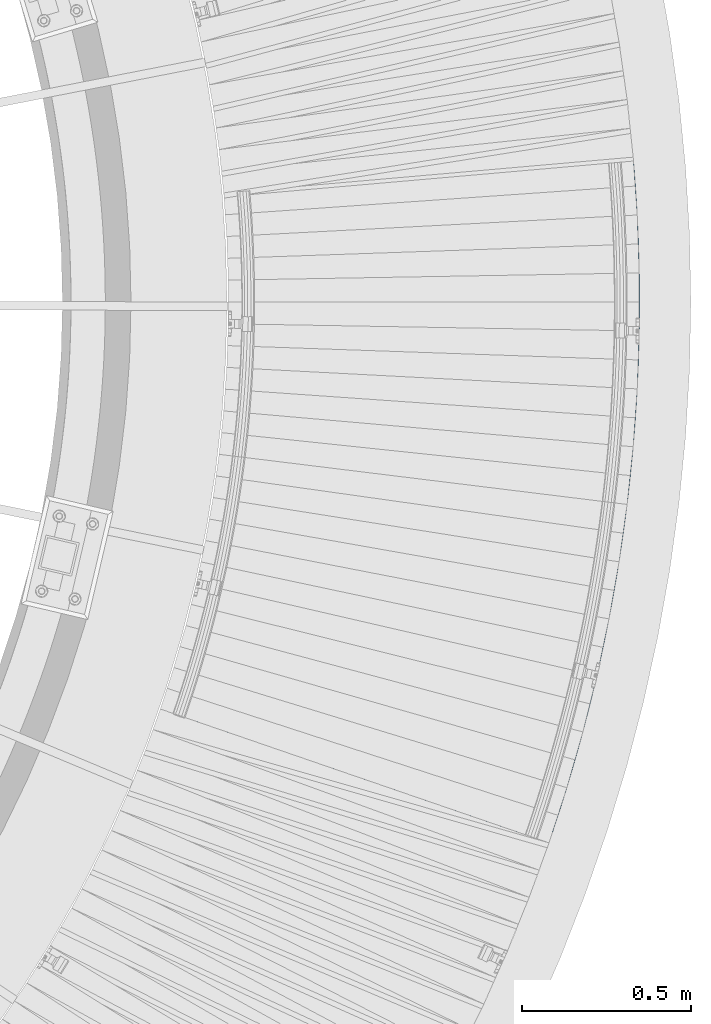
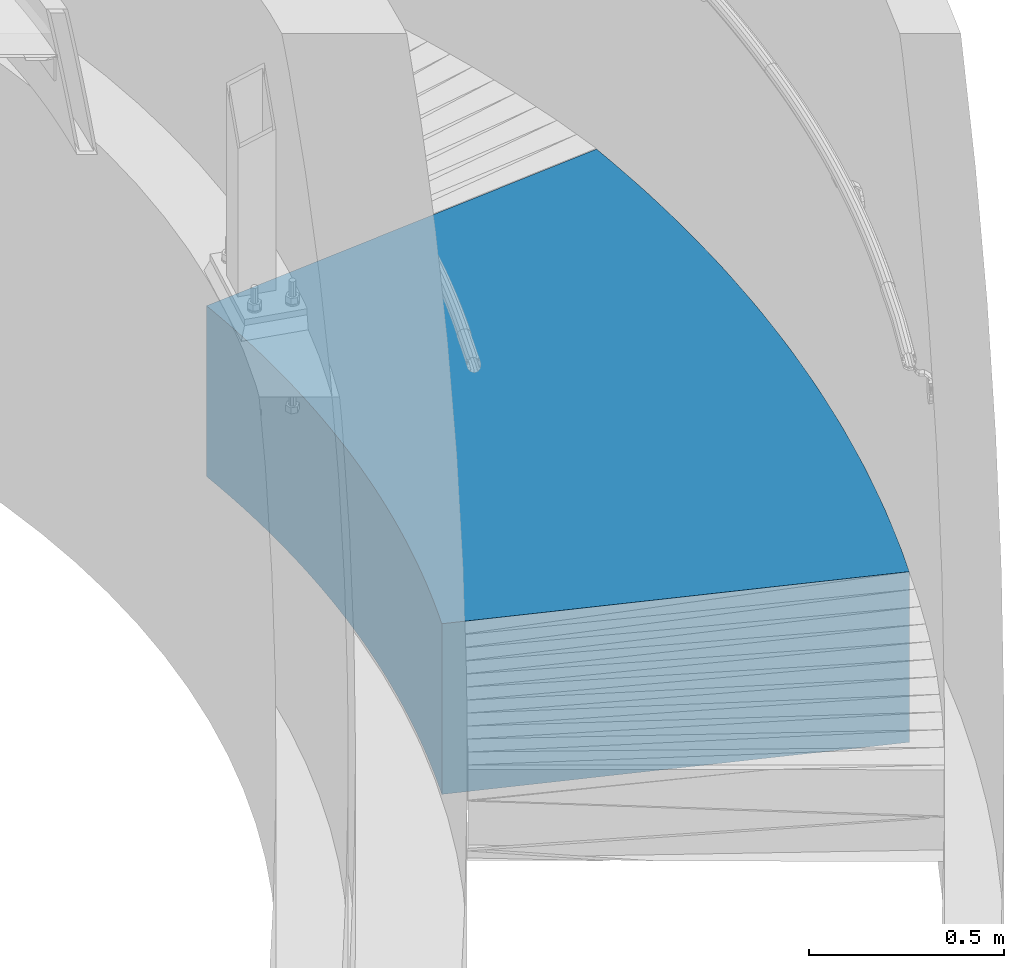
# One storey, part 365 of 975: 1 beam.
"""IFC2X3 building model written with IfcOpenShell, lengths in millimetres."""

from ifc_helpers import new_model, si_unit, frame, origin_with_axes, place, context, subcontext, project, spatial, faceted_brep, material, type_object, element, save


model = new_model("IFC2X3")

# Units and contexts
model_context = context("Model", 3, precision=1e-05, world=origin_with_axes())
body_context = subcontext(model_context, "Body", "Model", "MODEL_VIEW")
ifc_project = project(units=[si_unit("LENGTHUNIT", "METRE", prefix="MILLI"), si_unit("AREAUNIT", "SQUARE_METRE"), si_unit("VOLUMEUNIT", "CUBIC_METRE"), si_unit("MASSUNIT", "GRAM", prefix="KILO"), si_unit("TIMEUNIT", "SECOND"), si_unit("PLANEANGLEUNIT", "RADIAN"), si_unit("SOLIDANGLEUNIT", "STERADIAN"), si_unit("THERMODYNAMICTEMPERATUREUNIT", "DEGREE_CELSIUS"), si_unit("LUMINOUSINTENSITYUNIT", "LUMEN")], contexts=[model_context])

# Site, building, storey
site_placement = place(None, origin_with_axes())
site = spatial("IfcSite", under=ifc_project, at=site_placement, CompositionType="ELEMENT")
building_placement = place(site_placement, origin_with_axes())
building = spatial("IfcBuilding", under=site, at=building_placement, Name="Undefined", CompositionType="ELEMENT")
storey_placement = place(building_placement, origin_with_axes())
storey = spatial("IfcBuildingStorey", under=building, at=storey_placement, Name="Undefined", CompositionType="ELEMENT", Elevation=0.0)

# Beam
ifc_material = material(Name="STEEL/Zero_Density")
beam_type = type_object("IfcBeamType", PredefinedType="NOTDEFINED")
beam_placement = place(storey_placement, frame((39036.0687062099, 3779.93849345705, 266.7), z_axis=(0.992546151574695, -0.121869343947778, 0.0), x_axis=(-0.121869343947778, -0.992546151574695, 0.0)))
element("IfcBeam", 1, at=beam_placement, inside=storey, type_object=beam_type, material=ifc_material, Name="SLAB", context=body_context, shape_type="Brep", body=[
    faceted_brep([(-126.742966656699, 266.7, 596.278777421394), (-126.742966656699, -266.7, 596.278777421394), (-92.497715235615, -266.7, 603.430868701013), (-92.497715235615, 266.7, 603.430868701013), (126.742966656699, -266.7, -596.278777421401), (126.742966656699, 266.7, -596.278777421401), (152.515166179781, 266.7, -590.896275736726), (152.515166179781, -266.7, -590.896275736726), (-58.2025499977026, -266.7, 610.339652665614), (-58.2025499977026, 266.7, 610.339652665614), (178.324929709344, 266.7, -585.696881619049), (178.324929709344, -266.7, -585.696881619049), (-23.8591995818115, -266.7, 617.004781079726), (-23.8591995818115, 266.7, 617.004781079726), (204.170956310994, 266.7, -580.680857142448), (204.170956310994, -266.7, -580.680857142448), (10.5306049444407, -266.7, 623.425917989312), (10.5306049444407, 266.7, 623.425917989312), (230.051943222505, 266.7, -575.848455138337), (230.051943222505, -266.7, -575.848455138337), (44.9651301719314, -266.7, 629.602739738621), (44.9651301719314, 266.7, 629.602739738621), (255.966585919481, 266.7, -571.199919182662), (255.966585919481, -266.7, -571.199919182662), (79.4426404374026, -266.7, 635.534934986565), (79.4426404374026, 266.7, 635.534934986565), (281.913578181126, 266.7, -566.735483583696), (281.913578181126, -266.7, -566.735483583696), (113.961397910947, -266.7, 641.222204722399), (113.961397910947, 266.7, 641.222204722399), (307.89161215606, 266.7, -562.455373370125), (307.89161215606, -266.7, -562.455373370125), (148.519662683602, -266.7, 646.664262280785), (148.519662683602, 266.7, 646.664262280785), (333.899378428265, 266.7, -558.359804279789), (333.899378428265, -266.7, -558.359804279789), (183.115692855048, -266.7, 651.860833356222), (183.115692855048, 266.7, 651.860833356222), (359.935566083064, 266.7, -554.4489827488), (359.935566083064, -266.7, -554.4489827488), (217.747744621414, -266.7, 656.8116560169), (217.747744621414, 266.7, 656.8116560169), (385.998862773216, 266.7, -550.723105901074), (385.998862773216, -266.7, -550.723105901074), (252.414072363168, -266.7, 661.516480717895), (252.414072363168, 266.7, 661.516480717895), (412.087954785052, 266.7, -547.182361538471), (412.087954785052, -266.7, -547.182361538471), (287.112928733108, -266.7, 665.97507031374), (287.112928733108, 266.7, 665.97507031374), (438.201527104697, 266.7, -543.826928131282), (438.201527104697, -266.7, -543.826928131282), (321.842564744431, -266.7, 670.187200070402), (321.842564744431, 266.7, 670.187200070402), (464.338263484352, 266.7, -540.656974809266), (464.338263484352, -266.7, -540.656974809266), (356.601229858898, -266.7, 674.152657676575), (356.601229858898, 266.7, 674.152657676575), (490.496846508642, 266.7, -537.672661353077), (490.496846508642, -266.7, -537.672661353077), (391.387172075065, -266.7, 677.871243254398), (391.387172075065, 266.7, 677.871243254398), (516.675957661015, 266.7, -534.874138186256), (516.675957661015, -266.7, -534.874138186256), (426.19863801659, -266.7, 681.342769369548), (426.19863801659, 266.7, 681.342769369548), (542.874277390203, 266.7, -532.261546367634), (542.874277390203, -266.7, -532.261546367634), (461.033873020619, -266.7, 684.567061040645), (461.033873020619, 266.7, 684.567061040645), (569.090485176741, 266.7, -529.835017584228), (569.090485176741, -266.7, -529.835017584228), (495.89112122622, -266.7, 687.543955748108), (495.89112122622, 266.7, 687.543955748108), (595.323259599513, 266.7, -527.594674144602), (595.323259599513, -266.7, -527.594674144602), (530.768625662895, -266.7, 690.273303442344), (530.768625662895, 266.7, 690.273303442344), (621.571278402373, 266.7, -525.540628972638), (621.571278402373, -266.7, -525.540628972638), (565.664628339135, -266.7, 692.754966551292), (565.664628339135, 266.7, 692.754966551292), (647.833218560778, 266.7, -523.672985601996), (647.833218560778, -266.7, -523.672985601996), (600.577370331028, -266.7, 694.988819987368), (600.577370331028, 266.7, 694.988819987368), (674.107756348492, 266.7, -521.991838170718), (674.107756348492, -266.7, -521.991838170718), (635.505091870928, -266.7, 696.974751153779), (635.505091870928, 266.7, 696.974751153779), (700.393567404293, 266.7, -520.497271416614), (700.393567404293, -266.7, -520.497271416614), (670.446032436144, -266.7, 698.712659950186), (670.446032436144, 266.7, 698.712659950186), (726.689326798734, 266.7, -519.189360672928), (726.689326798734, -266.7, -519.189360672928), (705.398430837686, -266.7, 700.202458777727), (705.398430837686, 266.7, 700.202458777727), (752.993709100925, 266.7, -518.068171864572), (752.993709100925, -266.7, -518.068171864572), (740.360525309032, -266.7, 701.444072543505), (740.360525309032, 266.7, 701.444072543505), (779.30538844534, 266.7, -517.13376150476), (779.30538844534, -266.7, -517.13376150476), (775.330553594935, -266.7, 702.437438664281), (775.330553594935, 266.7, 702.437438664281), (805.623038598649, 266.7, -516.386176692213), (805.623038598649, -266.7, -516.386176692213), (810.306753040244, -266.7, 703.182507069716), (810.306753040244, 266.7, 703.182507069716), (831.945333026562, 266.7, -515.825455108738), (831.945333026562, -266.7, -515.825455108738), (845.287360678754, -266.7, 703.67924020483), (845.287360678754, 266.7, 703.67924020483), (858.270944960698, 266.7, -515.451625017369), (858.270944960698, -266.7, -515.451625017369), (880.270613322065, -266.7, 703.927613031898), (880.270613322065, 266.7, 703.927613031898), (884.598547465459, 266.7, -515.264705260917), (884.598547465459, -266.7, -515.264705260917), (915.254747648457, -266.7, 703.927613031767), (915.254747648457, 266.7, 703.927613031767), (910.926813504908, 266.7, -515.264705261012), (910.926813504908, -266.7, -515.264705261012), (950.238000291768, -266.7, 703.679240204452), (950.238000291768, 266.7, 703.679240204452), (937.254416009668, 266.7, -515.45162501766), (937.254416009668, -266.7, -515.45162501766), (985.218607930277, -266.7, 703.18250706909), (985.218607930277, 266.7, 703.18250706909), (963.580027943803, 266.7, -515.82545510921), (963.580027943803, -266.7, -515.82545510921), (1020.19480737559, -266.7, 702.437438663408), (1020.19480737559, 266.7, 702.437438663408), (989.902322371716, 266.7, -516.386176692875), (989.902322371716, -266.7, -516.386176692875), (1055.16483566149, -266.7, 701.44407254237), (1055.16483566149, 266.7, 701.44407254237), (1016.21997252502, 266.7, -517.133761505625), (1016.21997252502, -266.7, -517.133761505625), (1090.12693013284, -266.7, 700.202458776337), (1090.12693013284, 266.7, 700.202458776337), (1042.53165186944, 266.7, -518.068171865612), (1042.53165186944, -266.7, -518.068171865612), (1125.07932853438, -266.7, 698.712659948535), (1125.07932853438, 266.7, 698.712659948535), (1068.83603417163, 266.7, -519.189360674172), (1068.83603417163, -266.7, -519.189360674172), (1160.02026909959, -266.7, 696.974751151887), (1160.02026909959, 266.7, 696.974751151887), (1095.13179356607, 266.7, -520.497271418033), (1095.13179356607, -266.7, -520.497271418033), (1194.94799063949, -266.7, 694.988819985221), (1194.94799063949, 266.7, 694.988819985221), (1121.41760462187, 266.7, -521.991838172326), (1121.41760462187, -266.7, -521.991838172326), (1229.86073263139, -266.7, 692.754966548891), (1229.86073263139, 266.7, 692.754966548891), (1147.69214240959, 266.7, -523.6729856038), (1147.69214240959, -266.7, -523.6729856038), (1264.75673530762, -266.7, 690.273303439688), (1264.75673530762, 266.7, 690.273303439688), (1173.95408256799, 266.7, -525.540628974639), (1173.95408256799, -266.7, -525.540628974639), (1299.6342397443, -266.7, 687.543955745205), (1299.6342397443, 266.7, 687.543955745205), (1200.20210137085, 266.7, -527.594674146785), (1200.20210137085, -266.7, -527.594674146785), (1334.4914879499, -266.7, 684.56706103748), (1334.4914879499, 266.7, 684.56706103748), (1226.43487579362, 266.7, -529.835017586607), (1226.43487579362, -266.7, -529.835017586607), (1369.32672295393, -266.7, 681.342769366129), (1369.32672295393, 266.7, 681.342769366129), (1252.65108358016, 266.7, -532.261546370195), (1252.65108358016, -266.7, -532.261546370195), (1404.13818889545, -266.7, 677.871243250731), (1404.13818889545, 266.7, 677.871243250731), (1278.84940330935, 266.7, -534.874138189007), (1278.84940330935, -266.7, -534.874138189007), (1438.92413111162, -266.7, 674.152657672661), (1438.92413111162, 266.7, 674.152657672661), (1305.02851446172, 266.7, -537.672661356017), (1305.02851446172, -266.7, -537.672661356017), (1473.68279622609, -266.7, 670.187200066233), (1473.68279622609, 266.7, 670.187200066233), (1331.18709748601, 266.7, -540.656974812402), (1331.18709748601, -266.7, -540.656974812402), (1508.41243223741, -266.7, 665.975070309316), (1508.41243223741, 266.7, 665.975070309316), (1357.32383386566, 266.7, -543.826928134607), (1357.32383386566, -266.7, -543.826928134607), (1543.11128860735, -266.7, 661.516480713217), (1543.11128860735, 266.7, 661.516480713217), (1383.43740618531, 266.7, -547.182361541978), (1383.43740618531, -266.7, -547.182361541978), (1577.7776163491, -266.7, 656.811656011974), (1577.7776163491, 266.7, 656.811656011974), (1409.52649819714, 266.7, -550.723105904777), (1409.52649819714, -266.7, -550.723105904777), (1612.40966811547, -266.7, 651.860833351042), (1612.40966811547, 266.7, 651.860833351042), (1435.5897948873, 266.7, -554.448982752692), (1435.5897948873, -266.7, -554.448982752692), (1647.00569828691, -266.7, 646.664262275364), (1647.00569828691, 266.7, 646.664262275364), (1461.6259825421, 266.7, -558.359804283871), (1461.6259825421, -266.7, -558.359804283871), (1681.56396305957, -266.7, 641.222204716731), (1681.56396305957, 266.7, 641.222204716731), (1487.6337488143, 266.7, -562.455373374389), (1487.6337488143, -266.7, -562.455373374389), (1716.08272053311, -266.7, 635.534934980642), (1716.08272053311, 266.7, 635.534934980642), (1513.61178278923, 266.7, -566.735483588149), (1513.61178278923, -266.7, -566.735483588149), (1750.56023079858, -266.7, 629.602739732436), (1750.56023079858, 266.7, 629.602739732436), (1539.55877505088, 266.7, -571.199919187311), (1539.55877505088, -266.7, -571.199919187311), (1784.99475602607, -266.7, 623.425917982888), (1784.99475602607, 266.7, 623.425917982888), (1565.47341774785, 266.7, -575.848455143161), (1565.47341774785, -266.7, -575.848455143161), (1819.38456055232, -266.7, 617.004781073061), (1819.38456055232, 266.7, 617.004781073061), (1591.35440465936, 266.7, -580.680857147461), (1591.35440465936, -266.7, -580.680857147461), (1853.72791096821, -266.7, 610.339652658695), (1853.72791096821, 266.7, 610.339652658695), (1617.20043126101, 266.7, -585.696881624252), (1617.20043126101, -266.7, -585.696881624252), (1888.02307620613, -266.7, 603.430868693853), (1888.02307620613, 266.7, 603.430868693853), (1643.01019479058, 266.7, -590.896275742125), (1643.01019479058, -266.7, -590.896275742125), (1922.26832762721, 266.7, 596.27877741398), (1668.78239431366, 266.7, -596.278777426975), (1922.26832762721, -266.7, 596.27877741398), (1668.78239431366, -266.7, -596.278777426975)], [[[0, 1, 2, 3]], [[4, 5, 6, 7]], [[4, 1, 0, 5]], [[3, 2, 8, 9]], [[7, 6, 10, 11]], [[9, 8, 12, 13]], [[11, 10, 14, 15]], [[13, 12, 16, 17]], [[15, 14, 18, 19]], [[17, 16, 20, 21]], [[19, 18, 22, 23]], [[21, 20, 24, 25]], [[23, 22, 26, 27]], [[25, 24, 28, 29]], [[27, 26, 30, 31]], [[29, 28, 32, 33]], [[31, 30, 34, 35]], [[33, 32, 36, 37]], [[35, 34, 38, 39]], [[37, 36, 40, 41]], [[39, 38, 42, 43]], [[41, 40, 44, 45]], [[43, 42, 46, 47]], [[45, 44, 48, 49]], [[47, 46, 50, 51]], [[49, 48, 52, 53]], [[51, 50, 54, 55]], [[53, 52, 56, 57]], [[55, 54, 58, 59]], [[57, 56, 60, 61]], [[59, 58, 62, 63]], [[61, 60, 64, 65]], [[63, 62, 66, 67]], [[65, 64, 68, 69]], [[67, 66, 70, 71]], [[69, 68, 72, 73]], [[71, 70, 74, 75]], [[73, 72, 76, 77]], [[75, 74, 78, 79]], [[77, 76, 80, 81]], [[79, 78, 82, 83]], [[81, 80, 84, 85]], [[83, 82, 86, 87]], [[85, 84, 88, 89]], [[87, 86, 90, 91]], [[89, 88, 92, 93]], [[91, 90, 94, 95]], [[93, 92, 96, 97]], [[95, 94, 98, 99]], [[97, 96, 100, 101]], [[99, 98, 102, 103]], [[101, 100, 104, 105]], [[103, 102, 106, 107]], [[105, 104, 108, 109]], [[107, 106, 110, 111]], [[109, 108, 112, 113]], [[111, 110, 114, 115]], [[113, 112, 116, 117]], [[115, 114, 118, 119]], [[117, 116, 120, 121]], [[119, 118, 122, 123]], [[121, 120, 124, 125]], [[123, 122, 126, 127]], [[125, 124, 128, 129]], [[127, 126, 130, 131]], [[129, 128, 132, 133]], [[131, 130, 134, 135]], [[133, 132, 136, 137]], [[135, 134, 138, 139]], [[137, 136, 140, 141]], [[139, 138, 142, 143]], [[141, 140, 144, 145]], [[143, 142, 146, 147]], [[145, 144, 148, 149]], [[147, 146, 150, 151]], [[149, 148, 152, 153]], [[151, 150, 154, 155]], [[153, 152, 156, 157]], [[155, 154, 158, 159]], [[157, 156, 160, 161]], [[159, 158, 162, 163]], [[161, 160, 164, 165]], [[163, 162, 166, 167]], [[165, 164, 168, 169]], [[167, 166, 170, 171]], [[169, 168, 172, 173]], [[171, 170, 174, 175]], [[173, 172, 176, 177]], [[175, 174, 178, 179]], [[177, 176, 180, 181]], [[179, 178, 182, 183]], [[181, 180, 184, 185]], [[183, 182, 186, 187]], [[185, 184, 188, 189]], [[187, 186, 190, 191]], [[189, 188, 192, 193]], [[191, 190, 194, 195]], [[193, 192, 196, 197]], [[195, 194, 198, 199]], [[197, 196, 200, 201]], [[199, 198, 202, 203]], [[201, 200, 204, 205]], [[203, 202, 206, 207]], [[205, 204, 208, 209]], [[207, 206, 210, 211]], [[209, 208, 212, 213]], [[211, 210, 214, 215]], [[213, 212, 216, 217]], [[215, 214, 218, 219]], [[217, 216, 220, 221]], [[219, 218, 222, 223]], [[221, 220, 224, 225]], [[223, 222, 226, 227]], [[225, 224, 228, 229]], [[227, 226, 230, 231]], [[229, 228, 232, 233]], [[231, 230, 234, 235]], [[234, 230, 226, 222, 218, 214, 210, 206, 202, 198, 194, 190, 186, 182, 178, 174, 170, 166, 162, 158, 154, 150, 146, 142, 138, 134, 130, 126, 122, 118, 114, 110, 106, 102, 98, 94, 90, 86, 82, 78, 74, 70, 66, 62, 58, 54, 50, 46, 42, 38, 34, 30, 26, 22, 18, 14, 10, 6, 5, 0, 3, 9, 13, 17, 21, 25, 29, 33, 37, 41, 45, 49, 53, 57, 61, 65, 69, 73, 77, 81, 85, 89, 93, 97, 101, 105, 109, 113, 117, 121, 125, 129, 133, 137, 141, 145, 149, 153, 157, 161, 165, 169, 173, 177, 181, 185, 189, 193, 197, 201, 205, 209, 213, 217, 221, 225, 229, 233, 236, 237]], [[233, 232, 238, 236]], [[232, 228, 224, 220, 216, 212, 208, 204, 200, 196, 192, 188, 184, 180, 176, 172, 168, 164, 160, 156, 152, 148, 144, 140, 136, 132, 128, 124, 120, 116, 112, 108, 104, 100, 96, 92, 88, 84, 80, 76, 72, 68, 64, 60, 56, 52, 48, 44, 40, 36, 32, 28, 24, 20, 16, 12, 8, 2, 1, 4, 7, 11, 15, 19, 23, 27, 31, 35, 39, 43, 47, 51, 55, 59, 63, 67, 71, 75, 79, 83, 87, 91, 95, 99, 103, 107, 111, 115, 119, 123, 127, 131, 135, 139, 143, 147, 151, 155, 159, 163, 167, 171, 175, 179, 183, 187, 191, 195, 199, 203, 207, 211, 215, 219, 223, 227, 231, 235, 239, 238]], [[235, 234, 237, 239]], [[238, 239, 237, 236]]]),
])

save(model, "model.ifc")
